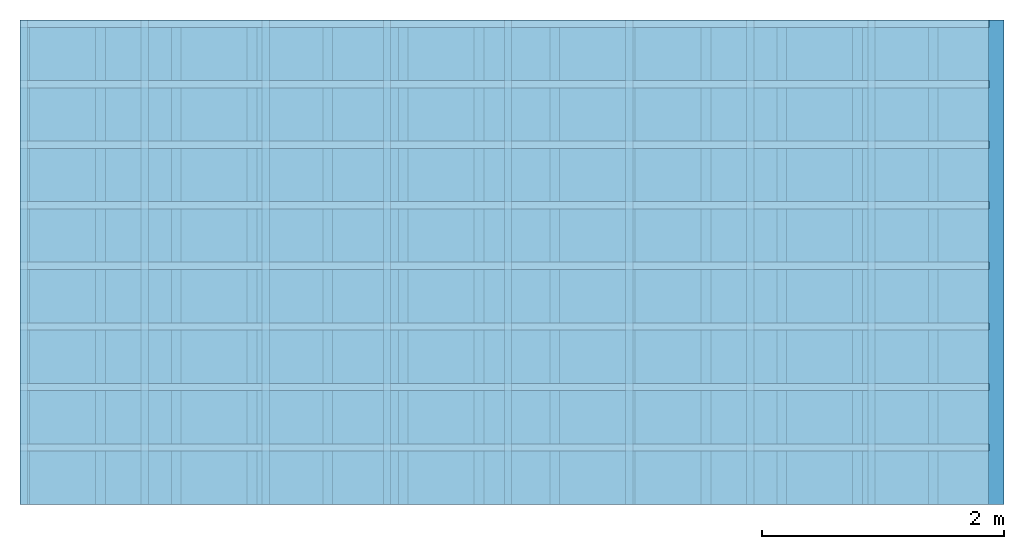
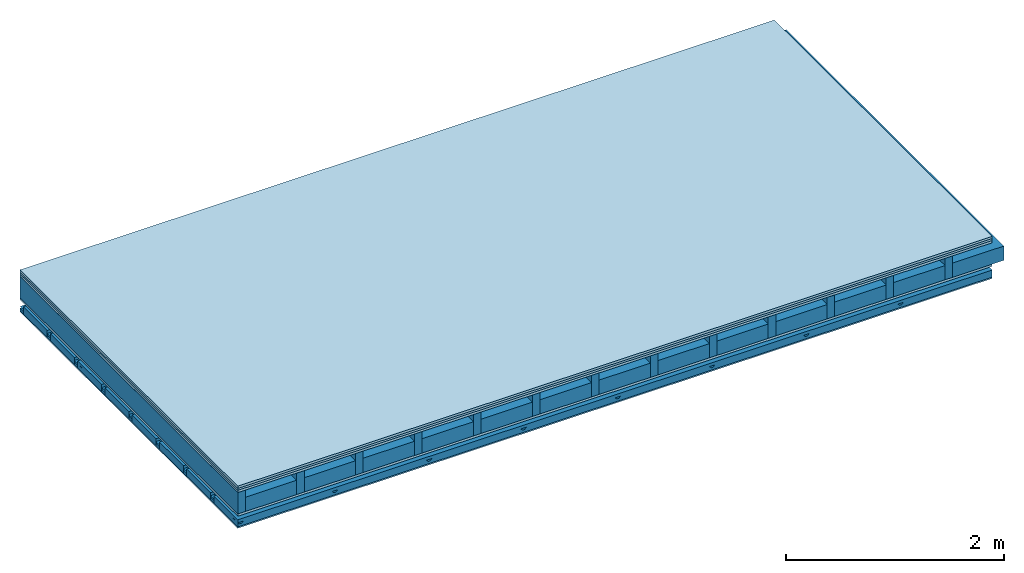
# One storey: 5 members, 5 plates, 1 element without a shape of its own.
"""IFC4 building model written with IfcOpenShell, lengths in metres."""

from ifc_helpers import new_model, si_unit, derived_unit, direction, frame, frame_2d, origin, origin_with_axes, place, context, project, spatial, polyline, rectangle, outline, extrude, material, layer, layer_set, type_object, element, aggregate, save


model = new_model("IFC4")

# Units and contexts
plan_context = context("Plan", 3, precision=1e-05, world=origin(), true_north=direction((0.0, 1.0)))
model_context = context("Model", 3, precision=1e-05, world=origin(), true_north=direction((0.0, 1.0)))
ifc_project = project(units=[si_unit("LENGTHUNIT", "METRE"), derived_unit("SOUNDPRESSUREUNIT", [(si_unit("PRESSUREUNIT", "PASCAL", prefix="MICRO"), 0)]), si_unit("ENERGYUNIT", "JOULE", prefix="MEGA"), si_unit("MASSUNIT", "GRAM", prefix="KILO"), derived_unit("THERMALTRANSMITTANCEUNIT", [(si_unit("POWERUNIT", "WATT"), 1), (si_unit("AREAUNIT", "SQUARE_METRE"), -1), (si_unit("THERMODYNAMICTEMPERATUREUNIT", "KELVIN"), -1)]), derived_unit("AREADENSITYUNIT", [(si_unit("MASSUNIT", "GRAM", prefix="KILO"), 1), (si_unit("AREAUNIT", "SQUARE_METRE"), -1)]), derived_unit("USERDEFINED", [(si_unit("ENERGYUNIT", "JOULE", prefix="MEGA"), 1), (si_unit("AREAUNIT", "SQUARE_METRE"), -1)])], contexts=[plan_context, model_context])

# Site, building, storey
site = spatial("IfcSite", under=ifc_project)
building_placement = place(None, origin())
building = spatial("IfcBuilding", under=site, at=building_placement)
storey_placement = place(building_placement, origin())
storey = spatial("IfcBuildingStorey", under=building, at=storey_placement)

# Slab, members, plates
ifc_material_1 = material(Name="Floor heating system Therm38 longitudinal", Category="03.007")
ifc_layer_1 = layer(ifc_material_1, 0.025, Name="On-material")
ifc_material_2 = material(Category="10.009")
ifc_layer_2 = layer(ifc_material_2, 0.022, Name="Impact sound insulation")
ifc_material_3 = material(Category="07.001")
ifc_layer_3 = layer(ifc_material_3, 0.025, Name="Sub-floor")
ifc_material_4 = material(Name="Rigid, of the art")
ifc_layer_4 = layer(ifc_material_4, 0.0, Name="Bond")
ifc_layer_5 = layer(None, 0.24, Name="Supporting structure")
ifc_layer_6 = layer(ifc_material_4, 0.0, Name="Bond")
ifc_layer_7 = layer(ifc_material_3, 0.025, Name="Lower layer 1")
ifc_layer_8 = layer(None, 0.093, Name="Coupling")
ifc_layer_9 = layer(None, 0.027, Name="Battens / profiles")
ifc_material_5 = material(Category="03.007")
ifc_layer_10 = layer(ifc_material_5, 0.015, Name="Ceiling covering 1st layer")
ifc_material_6 = material(Name="Glued joints")
ifc_layer_11 = layer(ifc_material_6, 0.0, Name="Surface / treatment")
ifc_layer_set = layer_set([ifc_layer_1, ifc_layer_2, ifc_layer_3, ifc_layer_4, ifc_layer_5, ifc_layer_6, ifc_layer_7, ifc_layer_8, ifc_layer_9, ifc_layer_10, ifc_layer_11])
slab_type = type_object("IfcSlabType", Name="A0352", PredefinedType="NOTDEFINED", material=ifc_layer_set)
slab_placement = place(None, frame((0.0, 0.0, 0.0), z_axis=(0.0, 0.0, -1.0), x_axis=(1.0, 0.0, 0.0)))
slab = element("IfcSlab", 1, at=slab_placement, inside=storey, type_object=slab_type, material=ifc_layer_set, Name="Slab #1")
ifc_material_7 = material()
member_1_placement = place(slab_placement, origin())
member_1 = element("IfcMember", 2, at=member_1_placement, material=ifc_material_7, Name="Supporting structure", context=plan_context, shape_type="SweptSolid", body=[
    extrude(rectangle(XDim=0.08, YDim=0.24, at=frame_2d((0.04, 0.12), x_axis=(1.0, 0.0))), frame((0.0, 4.0, 0.072), z_axis=(0.0, -1.0, 0.0), x_axis=(1.0, 0.0, 0.0)), (0.0, 0.0, 1.0), 4.0),
    extrude(rectangle(XDim=0.08, YDim=0.24, at=frame_2d((0.04, 0.12), x_axis=(1.0, 0.0))), frame((0.625, 4.0, 0.072), z_axis=(0.0, -1.0, 0.0), x_axis=(1.0, 0.0, 0.0)), (0.0, 0.0, 1.0), 4.0),
    extrude(rectangle(XDim=0.08, YDim=0.24, at=frame_2d((0.04, 0.12), x_axis=(1.0, 0.0))), frame((1.25, 4.0, 0.072), z_axis=(0.0, -1.0, 0.0), x_axis=(1.0, 0.0, 0.0)), (0.0, 0.0, 1.0), 4.0),
    extrude(rectangle(XDim=0.08, YDim=0.24, at=frame_2d((0.04, 0.12), x_axis=(1.0, 0.0))), frame((1.875, 4.0, 0.072), z_axis=(0.0, -1.0, 0.0), x_axis=(1.0, 0.0, 0.0)), (0.0, 0.0, 1.0), 4.0),
    extrude(rectangle(XDim=0.08, YDim=0.24, at=frame_2d((0.04, 0.12), x_axis=(1.0, 0.0))), frame((2.5, 4.0, 0.072), z_axis=(0.0, -1.0, 0.0), x_axis=(1.0, 0.0, 0.0)), (0.0, 0.0, 1.0), 4.0),
    extrude(rectangle(XDim=0.08, YDim=0.24, at=frame_2d((0.04, 0.12), x_axis=(1.0, 0.0))), frame((3.125, 4.0, 0.072), z_axis=(0.0, -1.0, 0.0), x_axis=(1.0, 0.0, 0.0)), (0.0, 0.0, 1.0), 4.0),
    extrude(rectangle(XDim=0.08, YDim=0.24, at=frame_2d((0.04, 0.12), x_axis=(1.0, 0.0))), frame((3.75, 4.0, 0.072), z_axis=(0.0, -1.0, 0.0), x_axis=(1.0, 0.0, 0.0)), (0.0, 0.0, 1.0), 4.0),
    extrude(rectangle(XDim=0.08, YDim=0.24, at=frame_2d((0.04, 0.12), x_axis=(1.0, 0.0))), frame((4.375, 4.0, 0.072), z_axis=(0.0, -1.0, 0.0), x_axis=(1.0, 0.0, 0.0)), (0.0, 0.0, 1.0), 4.0),
    extrude(rectangle(XDim=0.08, YDim=0.24, at=frame_2d((0.04, 0.12), x_axis=(1.0, 0.0))), frame((5.0, 4.0, 0.072), z_axis=(0.0, -1.0, 0.0), x_axis=(1.0, 0.0, 0.0)), (0.0, 0.0, 1.0), 4.0),
    extrude(rectangle(XDim=0.08, YDim=0.24, at=frame_2d((0.04, 0.12), x_axis=(1.0, 0.0))), frame((5.625, 4.0, 0.072), z_axis=(0.0, -1.0, 0.0), x_axis=(1.0, 0.0, 0.0)), (0.0, 0.0, 1.0), 4.0),
    extrude(rectangle(XDim=0.08, YDim=0.24, at=frame_2d((0.04, 0.12), x_axis=(1.0, 0.0))), frame((6.25, 4.0, 0.072), z_axis=(0.0, -1.0, 0.0), x_axis=(1.0, 0.0, 0.0)), (0.0, 0.0, 1.0), 4.0),
    extrude(rectangle(XDim=0.08, YDim=0.24, at=frame_2d((0.04, 0.12), x_axis=(1.0, 0.0))), frame((6.875, 4.0, 0.072), z_axis=(0.0, -1.0, 0.0), x_axis=(1.0, 0.0, 0.0)), (0.0, 0.0, 1.0), 4.0),
    extrude(rectangle(XDim=0.08, YDim=0.24, at=frame_2d((0.04, 0.12), x_axis=(1.0, 0.0))), frame((7.5, 4.0, 0.072), z_axis=(0.0, -1.0, 0.0), x_axis=(1.0, 0.0, 0.0)), (0.0, 0.0, 1.0), 4.0),
])
ifc_material_8 = material()
member_2_placement = place(slab_placement, origin())
member_2 = element("IfcMember", 3, at=member_2_placement, material=ifc_material_8, Name="Cavity", context=plan_context, shape_type="SweptSolid", body=[
    extrude(rectangle(XDim=0.545, YDim=0.16, at=frame_2d((0.2725, 0.08), x_axis=(1.0, 0.0))), frame((0.08, 4.0, 0.152), z_axis=(0.0, -1.0, 0.0), x_axis=(1.0, 0.0, 0.0)), (0.0, 0.0, 1.0), 4.0),
    extrude(rectangle(XDim=0.545, YDim=0.16, at=frame_2d((0.2725, 0.08), x_axis=(1.0, 0.0))), frame((0.705, 4.0, 0.152), z_axis=(0.0, -1.0, 0.0), x_axis=(1.0, 0.0, 0.0)), (0.0, 0.0, 1.0), 4.0),
    extrude(rectangle(XDim=0.545, YDim=0.16, at=frame_2d((0.2725, 0.08), x_axis=(1.0, 0.0))), frame((1.33, 4.0, 0.152), z_axis=(0.0, -1.0, 0.0), x_axis=(1.0, 0.0, 0.0)), (0.0, 0.0, 1.0), 4.0),
    extrude(rectangle(XDim=0.545, YDim=0.16, at=frame_2d((0.2725, 0.08), x_axis=(1.0, 0.0))), frame((1.955, 4.0, 0.152), z_axis=(0.0, -1.0, 0.0), x_axis=(1.0, 0.0, 0.0)), (0.0, 0.0, 1.0), 4.0),
    extrude(rectangle(XDim=0.545, YDim=0.16, at=frame_2d((0.2725, 0.08), x_axis=(1.0, 0.0))), frame((2.58, 4.0, 0.152), z_axis=(0.0, -1.0, 0.0), x_axis=(1.0, 0.0, 0.0)), (0.0, 0.0, 1.0), 4.0),
    extrude(rectangle(XDim=0.545, YDim=0.16, at=frame_2d((0.2725, 0.08), x_axis=(1.0, 0.0))), frame((3.205, 4.0, 0.152), z_axis=(0.0, -1.0, 0.0), x_axis=(1.0, 0.0, 0.0)), (0.0, 0.0, 1.0), 4.0),
    extrude(rectangle(XDim=0.545, YDim=0.16, at=frame_2d((0.2725, 0.08), x_axis=(1.0, 0.0))), frame((3.83, 4.0, 0.152), z_axis=(0.0, -1.0, 0.0), x_axis=(1.0, 0.0, 0.0)), (0.0, 0.0, 1.0), 4.0),
    extrude(rectangle(XDim=0.545, YDim=0.16, at=frame_2d((0.2725, 0.08), x_axis=(1.0, 0.0))), frame((4.455, 4.0, 0.152), z_axis=(0.0, -1.0, 0.0), x_axis=(1.0, 0.0, 0.0)), (0.0, 0.0, 1.0), 4.0),
    extrude(rectangle(XDim=0.545, YDim=0.16, at=frame_2d((0.2725, 0.08), x_axis=(1.0, 0.0))), frame((5.08, 4.0, 0.152), z_axis=(0.0, -1.0, 0.0), x_axis=(1.0, 0.0, 0.0)), (0.0, 0.0, 1.0), 4.0),
    extrude(rectangle(XDim=0.545, YDim=0.16, at=frame_2d((0.2725, 0.08), x_axis=(1.0, 0.0))), frame((5.705, 4.0, 0.152), z_axis=(0.0, -1.0, 0.0), x_axis=(1.0, 0.0, 0.0)), (0.0, 0.0, 1.0), 4.0),
    extrude(rectangle(XDim=0.545, YDim=0.16, at=frame_2d((0.2725, 0.08), x_axis=(1.0, 0.0))), frame((6.33, 4.0, 0.152), z_axis=(0.0, -1.0, 0.0), x_axis=(1.0, 0.0, 0.0)), (0.0, 0.0, 1.0), 4.0),
    extrude(rectangle(XDim=0.545, YDim=0.16, at=frame_2d((0.2725, 0.08), x_axis=(1.0, 0.0))), frame((6.955, 4.0, 0.152), z_axis=(0.0, -1.0, 0.0), x_axis=(1.0, 0.0, 0.0)), (0.0, 0.0, 1.0), 4.0),
    extrude(rectangle(XDim=0.545, YDim=0.16, at=frame_2d((0.2725, 0.08), x_axis=(1.0, 0.0))), frame((7.58, 4.0, 0.152), z_axis=(0.0, -1.0, 0.0), x_axis=(1.0, 0.0, 0.0)), (0.0, 0.0, 1.0), 4.0),
])
ifc_material_9 = material()
member_3_placement = place(slab_placement, origin())
member_3 = element("IfcMember", 4, at=member_3_placement, material=ifc_material_9, Name="Coupling", context=plan_context, shape_type="SweptSolid", body=[
    extrude(outline(polyline([(0.0, 0.0), (0.06, 0.0), (0.04, 0.02), (0.02, 0.02), (0.0, 0.0)])), frame((0.0, 4.0, 0.41), z_axis=(0.0, -1.0, 0.0), x_axis=(1.0, 0.0, 0.0)), (0.0, 0.0, 1.0), 4.0),
    extrude(outline(polyline([(0.0, 0.0), (0.06, 0.0), (0.04, 0.02), (0.02, 0.02), (0.0, 0.0)])), frame((1.0, 4.0, 0.41), z_axis=(0.0, -1.0, 0.0), x_axis=(1.0, 0.0, 0.0)), (0.0, 0.0, 1.0), 4.0),
    extrude(outline(polyline([(0.0, 0.0), (0.06, 0.0), (0.04, 0.02), (0.02, 0.02), (0.0, 0.0)])), frame((2.0, 4.0, 0.41), z_axis=(0.0, -1.0, 0.0), x_axis=(1.0, 0.0, 0.0)), (0.0, 0.0, 1.0), 4.0),
    extrude(outline(polyline([(0.0, 0.0), (0.06, 0.0), (0.04, 0.02), (0.02, 0.02), (0.0, 0.0)])), frame((3.0, 4.0, 0.41), z_axis=(0.0, -1.0, 0.0), x_axis=(1.0, 0.0, 0.0)), (0.0, 0.0, 1.0), 4.0),
    extrude(outline(polyline([(0.0, 0.0), (0.06, 0.0), (0.04, 0.02), (0.02, 0.02), (0.0, 0.0)])), frame((4.0, 4.0, 0.41), z_axis=(0.0, -1.0, 0.0), x_axis=(1.0, 0.0, 0.0)), (0.0, 0.0, 1.0), 4.0),
    extrude(outline(polyline([(0.0, 0.0), (0.06, 0.0), (0.04, 0.02), (0.02, 0.02), (0.0, 0.0)])), frame((5.0, 4.0, 0.41), z_axis=(0.0, -1.0, 0.0), x_axis=(1.0, 0.0, 0.0)), (0.0, 0.0, 1.0), 4.0),
    extrude(outline(polyline([(0.0, 0.0), (0.06, 0.0), (0.04, 0.02), (0.02, 0.02), (0.0, 0.0)])), frame((6.0, 4.0, 0.41), z_axis=(0.0, -1.0, 0.0), x_axis=(1.0, 0.0, 0.0)), (0.0, 0.0, 1.0), 4.0),
    extrude(outline(polyline([(0.0, 0.0), (0.06, 0.0), (0.04, 0.02), (0.02, 0.02), (0.0, 0.0)])), frame((7.0, 4.0, 0.41), z_axis=(0.0, -1.0, 0.0), x_axis=(1.0, 0.0, 0.0)), (0.0, 0.0, 1.0), 4.0),
])
ifc_material_10 = material()
member_4_placement = place(slab_placement, origin())
member_4 = element("IfcMember", 5, at=member_4_placement, material=ifc_material_10, Name="Battens / profiles", context=plan_context, shape_type="SweptSolid", body=[
    extrude(rectangle(XDim=0.06, YDim=0.027, at=frame_2d((0.03, 0.0135), x_axis=(1.0, 0.0))), frame((0.0, 0.0, 0.43), z_axis=(1.0, 0.0, 0.0), x_axis=(0.0, 1.0, 0.0)), (0.0, 0.0, 1.0), 8.0),
    extrude(rectangle(XDim=0.06, YDim=0.027, at=frame_2d((0.03, 0.0135), x_axis=(1.0, 0.0))), frame((0.0, 0.5, 0.43), z_axis=(1.0, 0.0, 0.0), x_axis=(0.0, 1.0, 0.0)), (0.0, 0.0, 1.0), 8.0),
    extrude(rectangle(XDim=0.06, YDim=0.027, at=frame_2d((0.03, 0.0135), x_axis=(1.0, 0.0))), frame((0.0, 1.0, 0.43), z_axis=(1.0, 0.0, 0.0), x_axis=(0.0, 1.0, 0.0)), (0.0, 0.0, 1.0), 8.0),
    extrude(rectangle(XDim=0.06, YDim=0.027, at=frame_2d((0.03, 0.0135), x_axis=(1.0, 0.0))), frame((0.0, 1.5, 0.43), z_axis=(1.0, 0.0, 0.0), x_axis=(0.0, 1.0, 0.0)), (0.0, 0.0, 1.0), 8.0),
    extrude(rectangle(XDim=0.06, YDim=0.027, at=frame_2d((0.03, 0.0135), x_axis=(1.0, 0.0))), frame((0.0, 2.0, 0.43), z_axis=(1.0, 0.0, 0.0), x_axis=(0.0, 1.0, 0.0)), (0.0, 0.0, 1.0), 8.0),
    extrude(rectangle(XDim=0.06, YDim=0.027, at=frame_2d((0.03, 0.0135), x_axis=(1.0, 0.0))), frame((0.0, 2.5, 0.43), z_axis=(1.0, 0.0, 0.0), x_axis=(0.0, 1.0, 0.0)), (0.0, 0.0, 1.0), 8.0),
    extrude(rectangle(XDim=0.06, YDim=0.027, at=frame_2d((0.03, 0.0135), x_axis=(1.0, 0.0))), frame((0.0, 3.0, 0.43), z_axis=(1.0, 0.0, 0.0), x_axis=(0.0, 1.0, 0.0)), (0.0, 0.0, 1.0), 8.0),
    extrude(rectangle(XDim=0.06, YDim=0.027, at=frame_2d((0.03, 0.0135), x_axis=(1.0, 0.0))), frame((0.0, 3.5, 0.43), z_axis=(1.0, 0.0, 0.0), x_axis=(0.0, 1.0, 0.0)), (0.0, 0.0, 1.0), 8.0),
])
member_5_placement = place(slab_placement, origin())
member_5 = element("IfcMember", 6, at=member_5_placement, material=ifc_material_8, Name="Cavity", context=plan_context, shape_type="SweptSolid", body=[
    extrude(rectangle(XDim=0.44, YDim=0.08, at=frame_2d((0.22, 0.04), x_axis=(1.0, 0.0))), frame((0.0, 0.06, 0.377), z_axis=(1.0, 0.0, 0.0), x_axis=(0.0, 1.0, 0.0)), (0.0, 0.0, 1.0), 8.0),
    extrude(rectangle(XDim=0.44, YDim=0.08, at=frame_2d((0.22, 0.04), x_axis=(1.0, 0.0))), frame((0.0, 0.56, 0.377), z_axis=(1.0, 0.0, 0.0), x_axis=(0.0, 1.0, 0.0)), (0.0, 0.0, 1.0), 8.0),
    extrude(rectangle(XDim=0.44, YDim=0.08, at=frame_2d((0.22, 0.04), x_axis=(1.0, 0.0))), frame((0.0, 1.06, 0.377), z_axis=(1.0, 0.0, 0.0), x_axis=(0.0, 1.0, 0.0)), (0.0, 0.0, 1.0), 8.0),
    extrude(rectangle(XDim=0.44, YDim=0.08, at=frame_2d((0.22, 0.04), x_axis=(1.0, 0.0))), frame((0.0, 1.56, 0.377), z_axis=(1.0, 0.0, 0.0), x_axis=(0.0, 1.0, 0.0)), (0.0, 0.0, 1.0), 8.0),
    extrude(rectangle(XDim=0.44, YDim=0.08, at=frame_2d((0.22, 0.04), x_axis=(1.0, 0.0))), frame((0.0, 2.06, 0.377), z_axis=(1.0, 0.0, 0.0), x_axis=(0.0, 1.0, 0.0)), (0.0, 0.0, 1.0), 8.0),
    extrude(rectangle(XDim=0.44, YDim=0.08, at=frame_2d((0.22, 0.04), x_axis=(1.0, 0.0))), frame((0.0, 2.56, 0.377), z_axis=(1.0, 0.0, 0.0), x_axis=(0.0, 1.0, 0.0)), (0.0, 0.0, 1.0), 8.0),
    extrude(rectangle(XDim=0.44, YDim=0.08, at=frame_2d((0.22, 0.04), x_axis=(1.0, 0.0))), frame((0.0, 3.06, 0.377), z_axis=(1.0, 0.0, 0.0), x_axis=(0.0, 1.0, 0.0)), (0.0, 0.0, 1.0), 8.0),
    extrude(rectangle(XDim=0.44, YDim=0.08, at=frame_2d((0.22, 0.04), x_axis=(1.0, 0.0))), frame((0.0, 3.56, 0.377), z_axis=(1.0, 0.0, 0.0), x_axis=(0.0, 1.0, 0.0)), (0.0, 0.0, 1.0), 8.0),
])
plate_1_placement = place(slab_placement, origin())
plate_1 = element("IfcPlate", 7, at=plate_1_placement, material=ifc_material_1, Name="On-material", context=plan_context, shape_type="SweptSolid", body=[
    extrude(rectangle(XDim=8.0, YDim=4.0, at=frame_2d((4.0, 2.0), x_axis=(1.0, 0.0))), origin_with_axes(), (0.0, 0.0, 1.0), 0.025),
])
plate_2_placement = place(slab_placement, origin())
plate_2 = element("IfcPlate", 8, at=plate_2_placement, material=ifc_material_2, Name="Impact sound insulation", context=plan_context, shape_type="SweptSolid", body=[
    extrude(rectangle(XDim=8.0, YDim=4.0, at=frame_2d((4.0, 2.0), x_axis=(1.0, 0.0))), frame((0.0, 0.0, 0.025), z_axis=(0.0, 0.0, 1.0), x_axis=(1.0, 0.0, 0.0)), (0.0, 0.0, 1.0), 0.022),
])
plate_3_placement = place(slab_placement, origin())
plate_3 = element("IfcPlate", 9, at=plate_3_placement, material=ifc_material_3, Name="Sub-floor", context=plan_context, shape_type="SweptSolid", body=[
    extrude(rectangle(XDim=8.0, YDim=4.0, at=frame_2d((4.0, 2.0), x_axis=(1.0, 0.0))), frame((0.0, 0.0, 0.047), z_axis=(0.0, 0.0, 1.0), x_axis=(1.0, 0.0, 0.0)), (0.0, 0.0, 1.0), 0.025),
])
plate_4_placement = place(slab_placement, origin())
plate_4 = element("IfcPlate", 10, at=plate_4_placement, material=ifc_material_3, Name="Lower layer 1", context=plan_context, shape_type="SweptSolid", body=[
    extrude(rectangle(XDim=8.0, YDim=4.0, at=frame_2d((4.0, 2.0), x_axis=(1.0, 0.0))), frame((0.0, 0.0, 0.312), z_axis=(0.0, 0.0, 1.0), x_axis=(1.0, 0.0, 0.0)), (0.0, 0.0, 1.0), 0.025),
])
plate_5_placement = place(slab_placement, origin())
plate_5 = element("IfcPlate", 11, at=plate_5_placement, material=ifc_material_5, Name="Ceiling covering 1st layer", context=plan_context, shape_type="SweptSolid", body=[
    extrude(rectangle(XDim=8.0, YDim=4.0, at=frame_2d((4.0, 2.0), x_axis=(1.0, 0.0))), frame((0.0, 0.0, 0.457), z_axis=(0.0, 0.0, 1.0), x_axis=(1.0, 0.0, 0.0)), (0.0, 0.0, 1.0), 0.015),
])
aggregate(slab, [plate_1, plate_2, plate_3, member_1, member_2, plate_4, member_3, member_4, member_5, plate_5])

save(model, "model.ifc")
